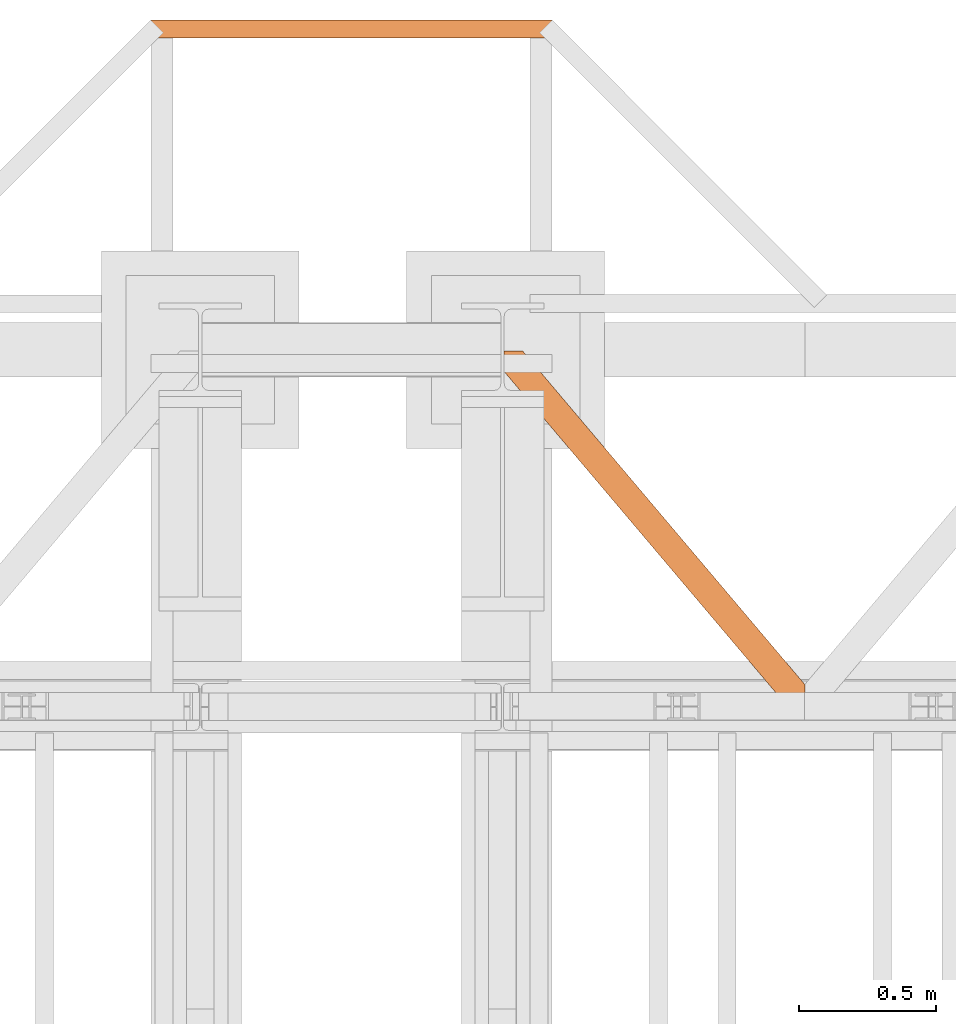
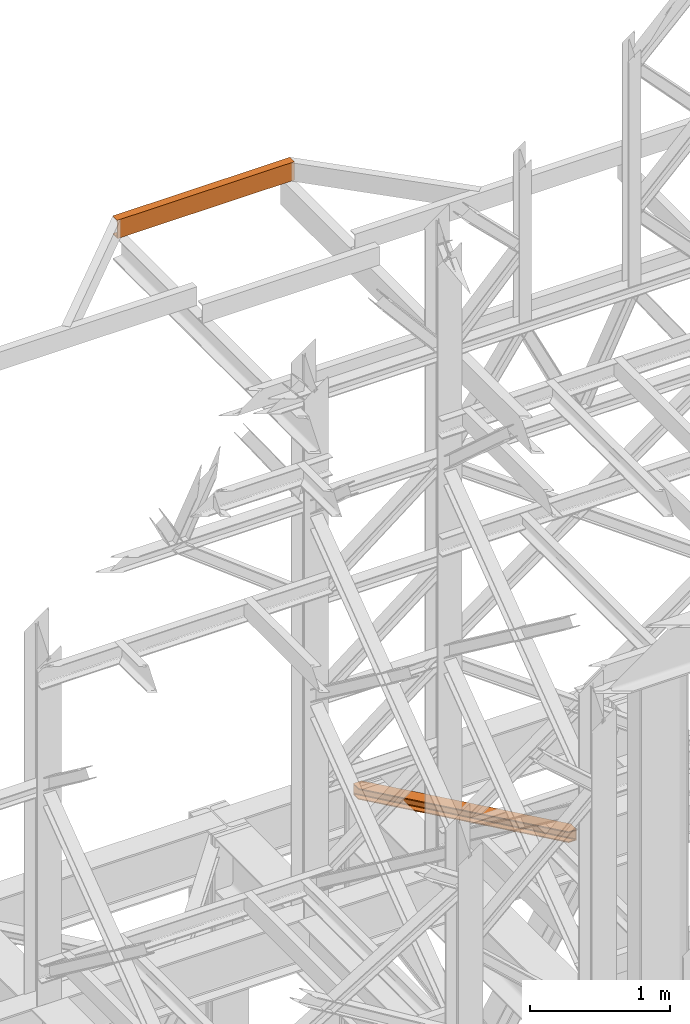
# One storey, part 196 of 208: 2 proxies.
"""IFC2X3 building model written with IfcOpenShell, lengths in millimetres."""

from ifc_helpers import new_model, entity, si_unit, converted_unit, frame, origin, origin_with_axes, place, context, subcontext, project, spatial, faceted_brep, element, save


model = new_model("IFC2X3")

# Units and contexts
model_context = context("Model", 3, precision=1e-05, world=origin())
plan_context = context("Plan", 3, precision=1e-05, world=origin())
body_context = subcontext(model_context, "Body", "Model", "MODEL_VIEW")
ifc_project = project(units=[si_unit("LENGTHUNIT", "METRE", prefix="MILLI"), converted_unit("PLANEANGLEUNIT", "DEGREE", entity("IfcPlaneAngleMeasure", 0.0174532925199433), si_unit("PLANEANGLEUNIT", "RADIAN"), dimensions=[0, 0, 0, 0, 0, 0, 0]), si_unit("AREAUNIT", "SQUARE_METRE"), si_unit("VOLUMEUNIT", "CUBIC_METRE")], contexts=[model_context, plan_context])

# Building, storey
building_placement = place(None, origin())
building = spatial("IfcBuilding", under=ifc_project, at=building_placement, CompositionType="COMPLEX")
storey_placement = place(building_placement, origin_with_axes())
storey = spatial("IfcBuildingStorey", under=building, at=storey_placement, Name="Geschoss", CompositionType="ELEMENT")

# Proxies
proxy_1_placement = place(storey_placement, frame((6599.254968580832, -13757.87439038569, 5101.990016164881), z_axis=(0.0, 0.0, 1.0), x_axis=(1.0, 0.0, 0.0)))
element("IfcBuildingElementProxy", 1, at=proxy_1_placement, inside=storey, context=body_context, shape_type="Brep", body=[
    faceted_brep([(1028.512359102908, 0.01000000000021828, 8.010001311302403), (1028.512359102908, 0.01000000000021828, 0.01000000000021828), (0.01000000000021828, 1215.512788030712, 0.01000000000021828), (0.01000000000021828, 1215.512788030712, 8.010001311303313), (1028.512359102908, 0.01000000000021828, 0.01000000000021828), (1094.009999947844, 0.01000000000021828, 0.01000000000021828), (1094.009999947845, 77.41630281674588, 0.01000000000021828), (67.46148411605282, 1290.610003345229, 0.01000000000021828), (0.01000000000021828, 1290.610003345229, 0.01000000000021828), (0.01000000000021828, 1215.512788030712, 0.01000000000021828), (1094.009999947845, 77.41630281674588, 0.01000000000021828), (1094.009999947846, 77.41630281674588, 8.010001311302403), (67.46148411605373, 1290.610003345229, 8.010001311302403), (67.46148411605282, 1290.610003345229, 0.01000000000021828), (1094.009999947846, 77.41630281674588, 8.010001311302403), (1094.009999947845, 22.45782827823496, 8.010001311302403), (20.95815950654378, 1290.610003345229, 8.010001311302403), (67.46148411605373, 1290.610003345229, 8.010001311302403), (1094.009999947845, 22.45782827823496, 8.010001311302403), (1094.009999947845, 12.84312897135897, 9.253033826351384), (12.82264470841801, 1290.610003345229, 9.253033826351384), (20.95815950654378, 1290.610003345229, 8.010001311302403), (1094.009999947845, 12.84312897135897, 9.253033826351384), (1094.009999947845, 5.804685632951077, 13.79946006298087), (6.86703880668756, 1290.610003345229, 13.79946006298087), (12.82264470841801, 1290.610003345229, 9.253033826351384), (1094.009999947845, 5.804685632951077, 13.79946006298087), (1094.009999947844, 3.880315357109794, 20.01000141561053), (5.238725496362349, 1290.610003345229, 20.01000141560962), (6.86703880668756, 1290.610003345229, 13.79946006298087), (1094.009999947844, 3.880315357109794, 20.01000141561053), (1094.009999947845, 3.880315357111613, 76.01000128150008), (5.238725496362349, 1290.610003345229, 76.01000128150008), (5.238725496362349, 1290.610003345229, 20.01000141560962), (1094.009999947845, 3.880315357111613, 76.01000128150008), (1094.009999947845, 5.804685632951077, 82.2205407714846), (6.867038806689379, 1290.610003345229, 82.2205407714846), (5.238725496362349, 1290.610003345229, 76.01000128150008), (1094.009999947845, 5.804685632951077, 82.2205407714846), (1094.009999947845, 12.84312897135897, 86.76696700811408), (12.82264470841983, 1290.610003345229, 86.76696700811317), (6.867038806689379, 1290.610003345229, 82.2205407714846), (1094.009999947845, 12.84312897135897, 86.76696700811408), (1094.009999947845, 22.45782827823496, 88.00999952316306), (20.95815950654469, 1290.610003345229, 88.00999952316306), (12.82264470841983, 1290.610003345229, 86.76696700811317), (1094.009999947845, 22.45782827823496, 88.00999952316306), (1094.009999947845, 77.41630281674588, 88.00999952316306), (67.46148411605463, 1290.610003345229, 88.00999952316397), (20.95815950654469, 1290.610003345229, 88.00999952316306), (1094.009999947845, 77.41630281674588, 88.00999952316306), (1094.009999947848, 77.41630281674406, 96.01000083446525), (67.46148411605463, 1290.610003345229, 96.01000083446525), (67.46148411605463, 1290.610003345229, 88.00999952316397), (1094.009999947848, 77.41630281674406, 96.01000083446525), (1094.009999947846, 0.01000000000021828, 96.01000083446525), (1028.51235910291, 0.01000000000021828, 96.01000083446525), (0.01000000000021828, 1215.512788030712, 96.01000083446525), (0.01000000000021828, 1290.610003345229, 96.01000083446525), (67.46148411605463, 1290.610003345229, 96.01000083446525), (1028.51235910291, 0.01000000000021828, 96.01000083446525), (1028.51235910291, 0.01000000000021828, 88.00999952316306), (0.01000000000021828, 1215.512788030712, 88.00999952316306), (0.01000000000021828, 1215.512788030712, 96.01000083446525), (1028.51235910291, 0.01000000000021828, 88.00999952316306), (1075.01568371242, 0.01000000000021828, 88.00999952316306), (0.01000000000021828, 1270.471262569223, 88.00999952316215), (0.01000000000021828, 1215.512788030712, 88.00999952316306), (1075.01568371242, 0.01000000000021828, 88.00999952316306), (1083.151198510546, 0.01000000000021828, 86.76696700811408), (0.01000000000021828, 1280.085961876101, 86.76696700811499), (0.01000000000021828, 1270.471262569223, 88.00999952316215), (1083.151198510546, 0.01000000000021828, 86.76696700811408), (1089.106804412275, 0.01000000000021828, 82.2205407714846), (0.01000000000021828, 1287.124405214508, 82.2205407714855), (0.01000000000021828, 1280.085961876101, 86.76696700811499), (1089.106804412275, 0.01000000000021828, 82.2205407714846), (1090.735117722603, 0.01000000000021828, 76.01000128150008), (0.01000000000021828, 1289.04877549035, 76.01000128150008), (0.01000000000021828, 1287.124405214508, 82.2205407714855), (1090.735117722603, 0.01000000000021828, 76.01000128150008), (1090.735117722602, 0.01000000000021828, 20.01000141561053), (0.01000000000021828, 1289.048775490348, 20.01000141561053), (0.01000000000021828, 1289.04877549035, 76.01000128150008), (1090.735117722602, 0.01000000000021828, 20.01000141561053), (1089.106804412275, 0.01000000000021828, 13.79946006298087), (0.01000000000021828, 1287.124405214508, 13.79946006298087), (0.01000000000021828, 1289.048775490348, 20.01000141561053), (1089.106804412275, 0.01000000000021828, 13.79946006298087), (1083.151198510544, 0.01000000000021828, 9.253033826351384), (0.01000000000021828, 1280.085961876099, 9.253033826351384), (0.01000000000021828, 1287.124405214508, 13.79946006298087), (1083.151198510544, 0.01000000000021828, 9.253033826351384), (1075.015683712418, 0.01000000000021828, 8.010001311302403), (0.01000000000021828, 1270.471262569225, 8.010001311302403), (0.01000000000021828, 1280.085961876099, 9.253033826351384), (1075.015683712418, 0.01000000000021828, 8.010001311302403), (1028.512359102908, 0.01000000000021828, 8.010001311302403), (0.01000000000021828, 1215.512788030712, 8.010001311303313), (0.01000000000021828, 1270.471262569225, 8.010001311302403), (1094.009999947845, 77.41630281674588, 0.01000000000021828), (1094.009999947844, 0.01000000000021828, 0.01000000000021828), (1094.009999947846, 0.01000000000021828, 96.01000083446525), (1094.009999947848, 77.41630281674406, 96.01000083446525), (1094.009999947845, 77.41630281674588, 88.00999952316306), (1094.009999947845, 22.45782827823496, 88.00999952316306), (1094.009999947845, 12.84312897135897, 86.76696700811408), (1094.009999947845, 5.804685632951077, 82.2205407714846), (1094.009999947845, 3.880315357111613, 76.01000128150008), (1094.009999947844, 3.880315357109794, 20.01000141561053), (1094.009999947845, 5.804685632951077, 13.79946006298087), (1094.009999947845, 12.84312897135897, 9.253033826351384), (1094.009999947845, 22.45782827823496, 8.010001311302403), (1094.009999947846, 77.41630281674588, 8.010001311302403), (1094.009999947846, 0.01000000000021828, 96.01000083446525), (1094.009999947844, 0.01000000000021828, 0.01000000000021828), (1028.512359102908, 0.01000000000021828, 0.01000000000021828), (1028.512359102908, 0.01000000000021828, 8.010001311302403), (1075.015683712418, 0.01000000000021828, 8.010001311302403), (1083.151198510544, 0.01000000000021828, 9.253033826351384), (1089.106804412275, 0.01000000000021828, 13.79946006298087), (1090.735117722602, 0.01000000000021828, 20.01000141561053), (1090.735117722603, 0.01000000000021828, 76.01000128150008), (1089.106804412275, 0.01000000000021828, 82.2205407714846), (1083.151198510546, 0.01000000000021828, 86.76696700811408), (1075.01568371242, 0.01000000000021828, 88.00999952316306), (1028.51235910291, 0.01000000000021828, 88.00999952316306), (1028.51235910291, 0.01000000000021828, 96.01000083446525), (0.01000000000021828, 1215.512788030712, 0.01000000000021828), (0.01000000000021828, 1290.610003345229, 0.01000000000021828), (0.01000000000021828, 1290.610003345229, 96.01000083446525), (0.01000000000021828, 1215.512788030712, 96.01000083446525), (0.01000000000021828, 1215.512788030712, 88.00999952316306), (0.01000000000021828, 1270.471262569223, 88.00999952316215), (0.01000000000021828, 1280.085961876101, 86.76696700811499), (0.01000000000021828, 1287.124405214508, 82.2205407714855), (0.01000000000021828, 1289.04877549035, 76.01000128150008), (0.01000000000021828, 1289.048775490348, 20.01000141561053), (0.01000000000021828, 1287.124405214508, 13.79946006298087), (0.01000000000021828, 1280.085961876099, 9.253033826351384), (0.01000000000021828, 1270.471262569225, 8.010001311302403), (0.01000000000021828, 1215.512788030712, 8.010001311303313), (67.46148411605282, 1290.610003345229, 0.01000000000021828), (67.46148411605373, 1290.610003345229, 8.010001311302403), (20.95815950654378, 1290.610003345229, 8.010001311302403), (12.82264470841801, 1290.610003345229, 9.253033826351384), (6.86703880668756, 1290.610003345229, 13.79946006298087), (5.238725496362349, 1290.610003345229, 20.01000141560962), (5.238725496362349, 1290.610003345229, 76.01000128150008), (6.867038806689379, 1290.610003345229, 82.2205407714846), (12.82264470841983, 1290.610003345229, 86.76696700811317), (20.95815950654469, 1290.610003345229, 88.00999952316306), (67.46148411605463, 1290.610003345229, 88.00999952316397), (67.46148411605463, 1290.610003345229, 96.01000083446525), (0.01000000000021828, 1290.610003345229, 96.01000083446525), (0.01000000000021828, 1290.610003345229, 0.01000000000021828)], [[[0, 1, 2, 3]], [[4, 5, 6, 7, 8, 9]], [[10, 11, 12, 13]], [[14, 15, 16, 17]], [[18, 19, 20, 21]], [[22, 23, 24, 25]], [[26, 27, 28, 29]], [[30, 31, 32, 33]], [[34, 35, 36, 37]], [[38, 39, 40, 41]], [[42, 43, 44, 45]], [[46, 47, 48, 49]], [[50, 51, 52, 53]], [[54, 55, 56, 57, 58, 59]], [[60, 61, 62, 63]], [[64, 65, 66, 67]], [[68, 69, 70, 71]], [[72, 73, 74, 75]], [[76, 77, 78, 79]], [[80, 81, 82, 83]], [[84, 85, 86, 87]], [[88, 89, 90, 91]], [[92, 93, 94, 95]], [[96, 97, 98, 99]], [[100, 101, 102, 103, 104, 105, 106, 107, 108, 109, 110, 111, 112, 113]], [[114, 115, 116, 117, 118, 119, 120, 121, 122, 123, 124, 125, 126, 127]], [[128, 129, 130, 131, 132, 133, 134, 135, 136, 137, 138, 139, 140, 141]], [[142, 143, 144, 145, 146, 147, 148, 149, 150, 151, 152, 153, 154, 155]]], orient=[[False], [False], [False], [False], [False], [False], [False], [False], [False], [False], [False], [False], [False], [False], [False], [False], [False], [False], [False], [False], [False], [False], [False], [False], [False], [False], [False], [False]]),
])
proxy_2_placement = place(storey_placement, frame((5313.254967038552, -11327.57438882777, 9699.99), z_axis=(0.0, 0.0, 1.0), x_axis=(1.0, 0.0, 0.0)))
element("IfcBuildingElementProxy", 2, at=proxy_2_placement, inside=storey, context=body_context, shape_type="Brep", body=[
    faceted_brep([(0.009999999999308784, 65.01000000000022, 0.01000000000021828), (1460.010002980231, 65.01000000000022, 0.01000000000021828), (1460.010002980231, 65.01000000000022, 3.132428070246533), (0.009999999999308784, 65.01000000000022, 3.132428070246533), (0.009999999999308784, 65.01000000000022, 3.132428070246533), (1460.010002980231, 65.01000000000022, 3.132428070246533), (1460.010002980231, 64.76726342282564, 4.748288908171162), (0.009999999999308784, 64.76726342282745, 4.748288908171162), (0.009999999999308784, 64.76726342282745, 4.748288908171162), (1460.010002980231, 64.76726342282564, 4.748288908171162), (1460.010002980231, 64.06053228585552, 6.221534443444398), (0.009999999999308784, 64.06053228585733, 6.221534443444398), (0.009999999999308784, 64.06053228585733, 6.221534443444398), (1460.010002980231, 64.06053228585552, 6.221534443444398), (1460.010002980231, 62.95215163846842, 7.422126703873801), (0.009999999999308784, 62.95215163846842, 7.422126703873801), (0.009999999999308784, 62.95215163846842, 7.422126703873801), (1460.010002980231, 62.95215163846842, 7.422126703873801), (1460.010002980231, 61.53995641148322, 8.244091391710754), (0.009999999999308784, 61.53995641148504, 8.244091391710754), (0.009999999999308784, 61.53995641148504, 8.244091391710754), (1460.010002980231, 61.53995641148322, 8.244091391710754), (1460.010002980231, 59.94859872255438, 8.614912102195376), (0.009999999999308784, 59.9485987225562, 8.614912102195376), (0.009999999999308784, 59.9485987225562, 8.614912102195376), (1460.010002980231, 59.94859872255438, 8.614912102195376), (1460.010002980231, 17.17267516602988, 12.0369859867169), (0.009999999999308784, 17.17267516602988, 12.0369859867169), (0.009999999999308784, 17.17267516602988, 12.0369859867169), (1460.010002980231, 17.17267516602988, 12.0369859867169), (1460.010002980231, 14.13462866898226, 12.74491643400506), (0.009999999999308784, 14.13462866898408, 12.74491643400506), (0.009999999999308784, 14.13462866898408, 12.74491643400506), (1460.010002980231, 14.13462866898226, 12.74491643400506), (1460.010002980231, 11.43861959928654, 14.31412174714933), (0.009999999999308784, 11.43861959928654, 14.31412174714933), (0.009999999999308784, 11.43861959928654, 14.31412174714933), (1460.010002980231, 11.43861959928654, 14.31412174714933), (1460.010002980231, 9.322620181546881, 16.60616151705835), (0.009999999999308784, 9.322620181546881, 16.60616151705835), (0.009999999999308784, 9.322620181546881, 16.60616151705835), (1460.010002980231, 9.322620181546881, 16.60616151705835), (1460.010002980231, 7.97340619278657, 19.41872117530875), (0.009999999999308784, 7.97340619278657, 19.41872117530875), (0.009999999999308784, 7.97340619278657, 19.41872117530875), (1460.010002980231, 7.97340619278657, 19.41872117530875), (1460.010002980231, 7.510000000000218, 22.50354641134618), (0.009999999999308784, 7.510000000000218, 22.50354641134618), (0.009999999999308784, 7.510000000000218, 22.50354641134618), (1460.010002980231, 7.510000000000218, 22.50354641134618), (1460.010002980231, 7.510000000000218, 137.5164535886524), (0.009999999999308784, 7.510000000000218, 137.5164535886524), (0.009999999999308784, 7.510000000000218, 137.5164535886524), (1460.010002980231, 7.510000000000218, 137.5164535886524), (1460.010002980231, 7.97340619278657, 140.6012788246917), (0.009999999999308784, 7.97340619278657, 140.6012788246917), (0.009999999999308784, 7.97340619278657, 140.6012788246917), (1460.010002980231, 7.97340619278657, 140.6012788246917), (1460.010002980231, 9.322620181546881, 143.4138384829403), (0.009999999999308784, 9.322620181546881, 143.4138384829403), (0.009999999999308784, 9.322620181546881, 143.4138384829403), (1460.010002980231, 9.322620181546881, 143.4138384829403), (1460.010002980231, 11.43861959928654, 145.7058782528493), (0.009999999999308784, 11.43861959928654, 145.7058782528493), (0.009999999999308784, 11.43861959928654, 145.7058782528493), (1460.010002980231, 11.43861959928654, 145.7058782528493), (1460.010002980231, 14.13462866898226, 147.2750835659936), (0.009999999999308784, 14.13462866898408, 147.2750835659936), (0.009999999999308784, 14.13462866898408, 147.2750835659936), (1460.010002980231, 14.13462866898226, 147.2750835659936), (1460.010002980231, 17.17267516602988, 147.9830140132817), (0.009999999999308784, 17.17267516602988, 147.9830140132817), (0.009999999999308784, 17.17267516602988, 147.9830140132817), (1460.010002980231, 17.17267516602988, 147.9830140132817), (1460.010002980231, 59.94859872255438, 151.4050878978032), (0.009999999999308784, 59.9485987225562, 151.4050878978032), (0.009999999999308784, 59.9485987225562, 151.4050878978032), (1460.010002980231, 59.94859872255438, 151.4050878978032), (1460.010002980231, 61.53995641148322, 151.7759086082879), (0.009999999999308784, 61.53995641148504, 151.7759086082879), (0.009999999999308784, 61.53995641148504, 151.7759086082879), (1460.010002980231, 61.53995641148322, 151.7759086082879), (1460.010002980231, 62.95215163846842, 152.5978732961248), (0.009999999999308784, 62.95215163846842, 152.5978732961248), (0.009999999999308784, 62.95215163846842, 152.5978732961248), (1460.010002980231, 62.95215163846842, 152.5978732961248), (1460.010002980231, 64.06053228585552, 153.7984655565542), (0.009999999999308784, 64.06053228585733, 153.7984655565542), (0.009999999999308784, 64.06053228585733, 153.7984655565542), (1460.010002980231, 64.06053228585552, 153.7984655565542), (1460.010002980231, 64.76726342282564, 155.2717110918275), (0.009999999999308784, 64.76726342282745, 155.2717110918275), (0.009999999999308784, 64.76726342282745, 155.2717110918275), (1460.010002980231, 64.76726342282564, 155.2717110918275), (1460.010002980231, 65.01000000000022, 156.8875719297521), (0.009999999999308784, 65.01000000000022, 156.8875719297521), (0.009999999999308784, 65.01000000000022, 156.8875719297521), (1460.010002980231, 65.01000000000022, 156.8875719297521), (1460.010002980231, 65.01000000000022, 160.0100000000002), (0.009999999999308784, 65.01000000000022, 160.0100000000002), (0.009999999999308784, 65.01000000000022, 160.0100000000002), (1460.010002980231, 65.01000000000022, 160.0100000000002), (1460.010002980231, 0.01000000000021828, 160.0100000000002), (0.009999999999308784, 0.01000000000021828, 160.0100000000002), (0.009999999999308784, 0.01000000000021828, 160.0100000000002), (1460.010002980231, 0.01000000000021828, 160.0100000000002), (1460.010002980231, 0.01000000000021828, 0.01000000000021828), (0.009999999999308784, 0.01000000000021828, 0.01000000000021828), (0.009999999999308784, 0.01000000000021828, 0.01000000000021828), (1460.010002980231, 0.01000000000021828, 0.01000000000021828), (1460.010002980231, 65.01000000000022, 0.01000000000021828), (0.009999999999308784, 65.01000000000022, 0.01000000000021828), (0.009999999999308784, 65.01000000000022, 0.01000000000021828), (0.009999999999308784, 65.01000000000022, 3.132428070246533), (0.009999999999308784, 64.76726342282745, 4.748288908171162), (0.009999999999308784, 64.06053228585733, 6.221534443444398), (0.009999999999308784, 62.95215163846842, 7.422126703873801), (0.009999999999308784, 61.53995641148504, 8.244091391710754), (0.009999999999308784, 59.9485987225562, 8.614912102195376), (0.009999999999308784, 17.17267516602988, 12.0369859867169), (0.009999999999308784, 14.13462866898408, 12.74491643400506), (0.009999999999308784, 11.43861959928654, 14.31412174714933), (0.009999999999308784, 9.322620181546881, 16.60616151705835), (0.009999999999308784, 7.97340619278657, 19.41872117530875), (0.009999999999308784, 7.510000000000218, 22.50354641134618), (0.009999999999308784, 7.510000000000218, 137.5164535886524), (0.009999999999308784, 7.97340619278657, 140.6012788246917), (0.009999999999308784, 9.322620181546881, 143.4138384829403), (0.009999999999308784, 11.43861959928654, 145.7058782528493), (0.009999999999308784, 14.13462866898408, 147.2750835659936), (0.009999999999308784, 17.17267516602988, 147.9830140132817), (0.009999999999308784, 59.9485987225562, 151.4050878978032), (0.009999999999308784, 61.53995641148504, 151.7759086082879), (0.009999999999308784, 62.95215163846842, 152.5978732961248), (0.009999999999308784, 64.06053228585733, 153.7984655565542), (0.009999999999308784, 64.76726342282745, 155.2717110918275), (0.009999999999308784, 65.01000000000022, 156.8875719297521), (0.009999999999308784, 65.01000000000022, 160.0100000000002), (0.009999999999308784, 0.01000000000021828, 160.0100000000002), (0.009999999999308784, 0.01000000000021828, 0.01000000000021828), (1460.010002980231, 65.01000000000022, 0.01000000000021828), (1460.010002980231, 0.01000000000021828, 0.01000000000021828), (1460.010002980231, 0.01000000000021828, 160.0100000000002), (1460.010002980231, 65.01000000000022, 160.0100000000002), (1460.010002980231, 65.01000000000022, 156.8875719297521), (1460.010002980231, 64.76726342282564, 155.2717110918275), (1460.010002980231, 64.06053228585552, 153.7984655565542), (1460.010002980231, 62.95215163846842, 152.5978732961248), (1460.010002980231, 61.53995641148322, 151.7759086082879), (1460.010002980231, 59.94859872255438, 151.4050878978032), (1460.010002980231, 17.17267516602988, 147.9830140132817), (1460.010002980231, 14.13462866898226, 147.2750835659936), (1460.010002980231, 11.43861959928654, 145.7058782528493), (1460.010002980231, 9.322620181546881, 143.4138384829403), (1460.010002980231, 7.97340619278657, 140.6012788246917), (1460.010002980231, 7.510000000000218, 137.5164535886524), (1460.010002980231, 7.510000000000218, 22.50354641134618), (1460.010002980231, 7.97340619278657, 19.41872117530875), (1460.010002980231, 9.322620181546881, 16.60616151705835), (1460.010002980231, 11.43861959928654, 14.31412174714933), (1460.010002980231, 14.13462866898226, 12.74491643400506), (1460.010002980231, 17.17267516602988, 12.0369859867169), (1460.010002980231, 59.94859872255438, 8.614912102195376), (1460.010002980231, 61.53995641148322, 8.244091391710754), (1460.010002980231, 62.95215163846842, 7.422126703873801), (1460.010002980231, 64.06053228585552, 6.221534443444398), (1460.010002980231, 64.76726342282564, 4.748288908171162), (1460.010002980231, 65.01000000000022, 3.132428070246533)], [[[0, 1, 2, 3]], [[4, 5, 6, 7]], [[8, 9, 10, 11]], [[12, 13, 14, 15]], [[16, 17, 18, 19]], [[20, 21, 22, 23]], [[24, 25, 26, 27]], [[28, 29, 30, 31]], [[32, 33, 34, 35]], [[36, 37, 38, 39]], [[40, 41, 42, 43]], [[44, 45, 46, 47]], [[48, 49, 50, 51]], [[52, 53, 54, 55]], [[56, 57, 58, 59]], [[60, 61, 62, 63]], [[64, 65, 66, 67]], [[68, 69, 70, 71]], [[72, 73, 74, 75]], [[76, 77, 78, 79]], [[80, 81, 82, 83]], [[84, 85, 86, 87]], [[88, 89, 90, 91]], [[92, 93, 94, 95]], [[96, 97, 98, 99]], [[100, 101, 102, 103]], [[104, 105, 106, 107]], [[108, 109, 110, 111]], [[112, 113, 114, 115, 116, 117, 118, 119, 120, 121, 122, 123, 124, 125, 126, 127, 128, 129, 130, 131, 132, 133, 134, 135, 136, 137, 138, 139]], [[140, 141, 142, 143, 144, 145, 146, 147, 148, 149, 150, 151, 152, 153, 154, 155, 156, 157, 158, 159, 160, 161, 162, 163, 164, 165, 166, 167]]], orient=[[False], [False], [False], [False], [False], [False], [False], [False], [False], [False], [False], [False], [False], [False], [False], [False], [False], [False], [False], [False], [False], [False], [False], [False], [False], [False], [False], [False], [False], [False]]),
])

save(model, "model.ifc")
